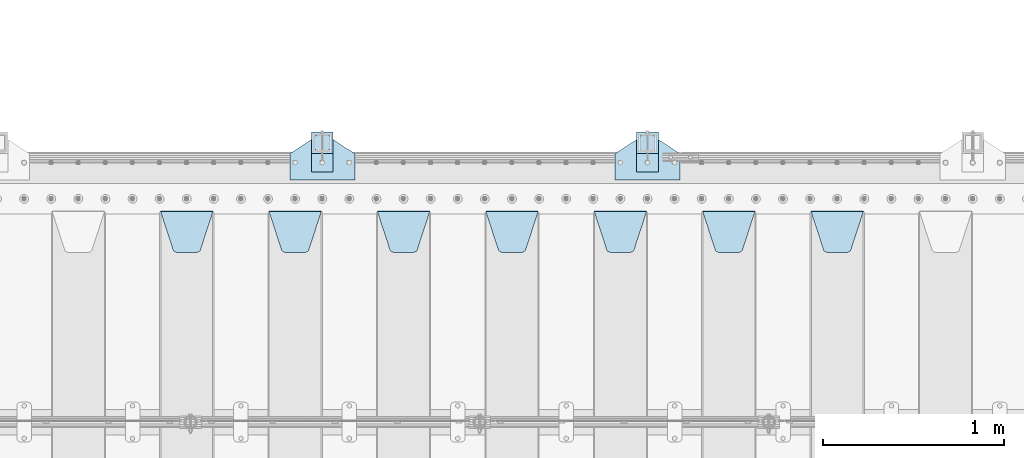
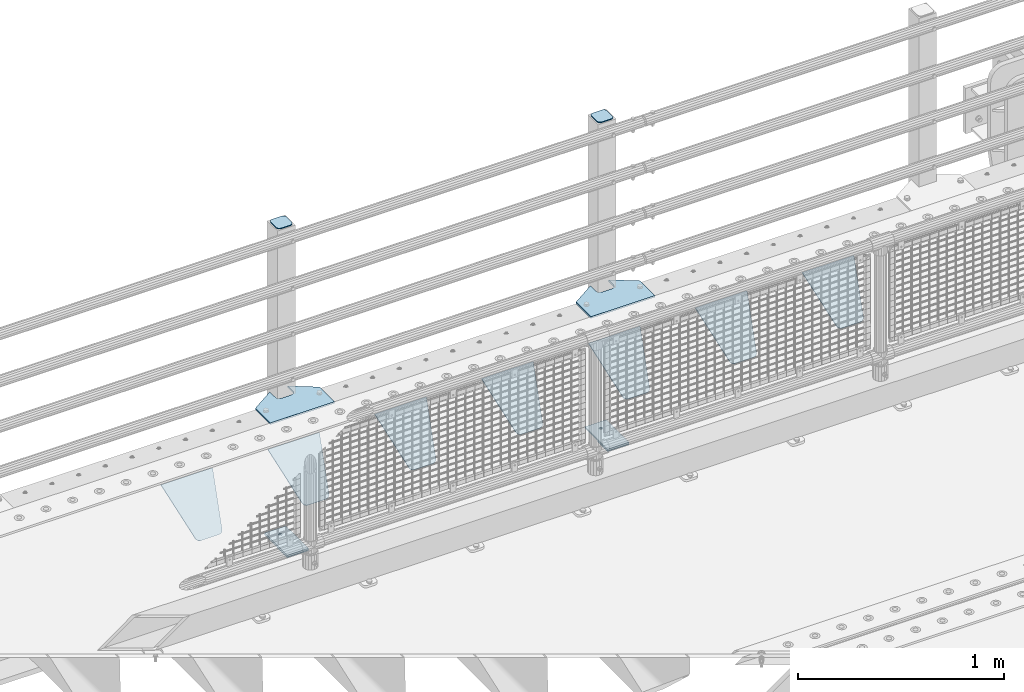
# One storey, part 230 of 257: 15 plates.
"""IFC2X3 building model written with IfcOpenShell, lengths in millimetres."""

from ifc_helpers import new_model, si_unit, frame, origin_with_axes, place, context, subcontext, project, spatial, faceted_brep, material, type_object, element, save


model = new_model("IFC2X3")

# Units and contexts
model_context = context("Model", 3, precision=1e-05, world=origin_with_axes())
body_context = subcontext(model_context, "Body", "Model", "MODEL_VIEW")
ifc_project = project(units=[si_unit("LENGTHUNIT", "METRE", prefix="MILLI"), si_unit("AREAUNIT", "SQUARE_METRE"), si_unit("VOLUMEUNIT", "CUBIC_METRE"), si_unit("MASSUNIT", "GRAM", prefix="KILO"), si_unit("TIMEUNIT", "SECOND"), si_unit("PLANEANGLEUNIT", "RADIAN"), si_unit("SOLIDANGLEUNIT", "STERADIAN"), si_unit("THERMODYNAMICTEMPERATUREUNIT", "DEGREE_CELSIUS"), si_unit("LUMINOUSINTENSITYUNIT", "LUMEN")], contexts=[model_context])

# Site, building, storey
site_placement = place(None, origin_with_axes())
site = spatial("IfcSite", under=ifc_project, at=site_placement, CompositionType="ELEMENT")
building_placement = place(site_placement, origin_with_axes())
building = spatial("IfcBuilding", under=site, at=building_placement, Name="Standard", CompositionType="ELEMENT")
storey_placement = place(building_placement, origin_with_axes())
storey = spatial("IfcBuildingStorey", under=building, at=storey_placement, Name="Undefined", CompositionType="ELEMENT", Elevation=0.0)

# Plates
ifc_material_1 = material(Name="STEEL/S355N")
plate_type_1 = type_object("IfcPlateType", PredefinedType="NOTDEFINED")
plate_1_placement = place(storey_placement, frame((52905.0, 11831.7677669559, -1.767766952965), z_axis=(0.0, -0.707106781186548, -0.707106781186547), x_axis=(1.0, 0.0, 0.0)))
element("IfcPlate", 1, at=plate_1_placement, inside=storey, type_object=plate_type_1, material=ifc_material_1, context=body_context, shape_type="Brep", body=[
    faceted_brep([(0.0, -2.5, 0.0), (69.345504679477, -2.50000000000091, 300.17173142483), (69.345504679477, 2.5, 300.171731424831), (0.0, 2.5, 0.0), (70.927406119954, -2.50000000000091, 304.8974424154), (70.927406119954, 2.5, 304.8974424154), (73.3818627772271, -2.50000000000091, 309.234538108527), (73.3818627772271, 2.49999999999909, 309.234538108527), (76.6187032999587, -2.5, 313.023683126103), (76.6187032999587, 2.5, 313.023683126103), (80.5190132705029, -2.5, 316.125672595372), (80.5190132705029, 2.5, 316.125672595371), (84.9395038596849, -2.5, 318.426546230476), (84.9395038596849, 2.5, 318.426546230477), (89.7177759439219, -2.5, 319.841774983275), (89.7177759439219, 2.5, 319.841774983275), (94.6782862926484, -2.5, 320.319366455079), (94.6782862926484, 2.5, 320.319366455079), (195.321713707352, -2.5, 320.319366455079), (195.321713707352, 2.5, 320.319366455079), (200.282224056078, -2.5, 319.841774983275), (200.282224056078, 2.49999999999909, 319.841774983275), (205.060496140315, -2.5, 318.426546230476), (205.060496140315, 2.49999999999909, 318.426546230475), (209.480986729497, -2.5, 316.125672595371), (209.480986729497, 2.5, 316.125672595371), (213.381296700041, -2.50000000000091, 313.023683126102), (213.381296700041, 2.5, 313.023683126103), (216.618137222766, -2.50000000000091, 309.234538108527), (216.618137222766, 2.5, 309.234538108527), (219.072593880039, -2.5, 304.897442415399), (219.072593880039, 2.5, 304.897442415399), (220.654495320523, -2.50000000000091, 300.17173142483), (220.654495320523, 2.5, 300.171731424831), (290.0, -2.50000000000091, 0.0), (290.0, 2.5, 9.09494701772928e-13)], [[[0, 1, 2, 3]], [[1, 4, 5, 2]], [[4, 6, 7, 5]], [[6, 8, 9, 7]], [[8, 10, 11, 9]], [[10, 12, 13, 11]], [[12, 14, 15, 13]], [[14, 16, 17, 15]], [[16, 18, 19, 17]], [[18, 20, 21, 19]], [[20, 22, 23, 21]], [[22, 24, 25, 23]], [[24, 26, 27, 25]], [[26, 28, 29, 27]], [[28, 30, 31, 29]], [[30, 32, 33, 31]], [[32, 34, 35, 33]], [[34, 0, 3, 35]], [[5, 7, 9, 11, 13, 15, 17, 19, 21, 23, 25, 27, 29, 31, 33, 35, 3, 2]], [[34, 32, 30, 28, 26, 24, 22, 20, 18, 16, 14, 12, 10, 8, 6, 4, 1, 0]]]),
])
plate_2_placement = place(storey_placement, frame((52305.0, 11831.7677669559, -1.767766952965), z_axis=(0.0, -0.707106781186548, -0.707106781186547), x_axis=(1.0, 0.0, 0.0)))
element("IfcPlate", 2, at=plate_2_placement, inside=storey, type_object=plate_type_1, material=ifc_material_1, context=body_context, shape_type="Brep", body=[
    faceted_brep([(0.0, -2.5, 0.0), (69.345504679477, -2.50000000000091, 300.17173142483), (69.345504679477, 2.5, 300.171731424831), (0.0, 2.5, 0.0), (70.927406119954, -2.50000000000091, 304.8974424154), (70.927406119954, 2.5, 304.8974424154), (73.3818627772271, -2.50000000000091, 309.234538108527), (73.3818627772271, 2.49999999999909, 309.234538108527), (76.6187032999587, -2.5, 313.023683126103), (76.6187032999587, 2.5, 313.023683126103), (80.5190132705029, -2.5, 316.125672595372), (80.5190132705029, 2.5, 316.125672595371), (84.9395038596849, -2.5, 318.426546230476), (84.9395038596849, 2.5, 318.426546230477), (89.7177759439219, -2.5, 319.841774983275), (89.7177759439219, 2.5, 319.841774983275), (94.6782862926484, -2.5, 320.319366455079), (94.6782862926484, 2.5, 320.319366455079), (195.321713707352, -2.5, 320.319366455079), (195.321713707352, 2.5, 320.319366455079), (200.282224056078, -2.5, 319.841774983275), (200.282224056078, 2.49999999999909, 319.841774983275), (205.060496140315, -2.5, 318.426546230476), (205.060496140315, 2.49999999999909, 318.426546230475), (209.480986729497, -2.5, 316.125672595371), (209.480986729497, 2.5, 316.125672595371), (213.381296700041, -2.50000000000091, 313.023683126102), (213.381296700041, 2.5, 313.023683126103), (216.618137222766, -2.50000000000091, 309.234538108527), (216.618137222766, 2.5, 309.234538108527), (219.072593880039, -2.5, 304.897442415399), (219.072593880039, 2.5, 304.897442415399), (220.654495320523, -2.50000000000091, 300.17173142483), (220.654495320523, 2.5, 300.171731424831), (290.0, -2.50000000000091, 0.0), (290.0, 2.5, 9.09494701772928e-13)], [[[0, 1, 2, 3]], [[1, 4, 5, 2]], [[4, 6, 7, 5]], [[6, 8, 9, 7]], [[8, 10, 11, 9]], [[10, 12, 13, 11]], [[12, 14, 15, 13]], [[14, 16, 17, 15]], [[16, 18, 19, 17]], [[18, 20, 21, 19]], [[20, 22, 23, 21]], [[22, 24, 25, 23]], [[24, 26, 27, 25]], [[26, 28, 29, 27]], [[28, 30, 31, 29]], [[30, 32, 33, 31]], [[32, 34, 35, 33]], [[34, 0, 3, 35]], [[5, 7, 9, 11, 13, 15, 17, 19, 21, 23, 25, 27, 29, 31, 33, 35, 3, 2]], [[34, 32, 30, 28, 26, 24, 22, 20, 18, 16, 14, 12, 10, 8, 6, 4, 1, 0]]]),
])
plate_3_placement = place(storey_placement, frame((51705.0, 11831.7677669559, -1.767766952965), z_axis=(0.0, -0.707106781186548, -0.707106781186547), x_axis=(1.0, 0.0, 0.0)))
element("IfcPlate", 3, at=plate_3_placement, inside=storey, type_object=plate_type_1, material=ifc_material_1, context=body_context, shape_type="Brep", body=[
    faceted_brep([(0.0, -2.5, 0.0), (69.345504679477, -2.50000000000091, 300.17173142483), (69.345504679477, 2.5, 300.171731424831), (0.0, 2.5, 0.0), (70.927406119954, -2.50000000000091, 304.8974424154), (70.927406119954, 2.5, 304.8974424154), (73.3818627772271, -2.50000000000091, 309.234538108527), (73.3818627772271, 2.49999999999909, 309.234538108527), (76.6187032999587, -2.5, 313.023683126103), (76.6187032999587, 2.5, 313.023683126103), (80.5190132705029, -2.5, 316.125672595372), (80.5190132705029, 2.5, 316.125672595371), (84.9395038596849, -2.5, 318.426546230476), (84.9395038596849, 2.5, 318.426546230477), (89.7177759439219, -2.5, 319.841774983275), (89.7177759439219, 2.5, 319.841774983275), (94.6782862926484, -2.5, 320.319366455079), (94.6782862926484, 2.5, 320.319366455079), (195.321713707352, -2.5, 320.319366455079), (195.321713707352, 2.5, 320.319366455079), (200.282224056078, -2.5, 319.841774983275), (200.282224056078, 2.49999999999909, 319.841774983275), (205.060496140315, -2.5, 318.426546230476), (205.060496140315, 2.49999999999909, 318.426546230475), (209.480986729497, -2.5, 316.125672595371), (209.480986729497, 2.5, 316.125672595371), (213.381296700041, -2.50000000000091, 313.023683126102), (213.381296700041, 2.5, 313.023683126103), (216.618137222766, -2.50000000000091, 309.234538108527), (216.618137222766, 2.5, 309.234538108527), (219.072593880039, -2.5, 304.897442415399), (219.072593880039, 2.5, 304.897442415399), (220.654495320523, -2.50000000000091, 300.17173142483), (220.654495320523, 2.5, 300.171731424831), (290.0, -2.50000000000091, 0.0), (290.0, 2.5, 9.09494701772928e-13)], [[[0, 1, 2, 3]], [[1, 4, 5, 2]], [[4, 6, 7, 5]], [[6, 8, 9, 7]], [[8, 10, 11, 9]], [[10, 12, 13, 11]], [[12, 14, 15, 13]], [[14, 16, 17, 15]], [[16, 18, 19, 17]], [[18, 20, 21, 19]], [[20, 22, 23, 21]], [[22, 24, 25, 23]], [[24, 26, 27, 25]], [[26, 28, 29, 27]], [[28, 30, 31, 29]], [[30, 32, 33, 31]], [[32, 34, 35, 33]], [[34, 0, 3, 35]], [[5, 7, 9, 11, 13, 15, 17, 19, 21, 23, 25, 27, 29, 31, 33, 35, 3, 2]], [[34, 32, 30, 28, 26, 24, 22, 20, 18, 16, 14, 12, 10, 8, 6, 4, 1, 0]]]),
])
plate_4_placement = place(storey_placement, frame((51105.0, 11831.7677669559, -1.767766952965), z_axis=(0.0, -0.707106781186548, -0.707106781186547), x_axis=(1.0, 0.0, 0.0)))
element("IfcPlate", 4, at=plate_4_placement, inside=storey, type_object=plate_type_1, material=ifc_material_1, context=body_context, shape_type="Brep", body=[
    faceted_brep([(0.0, -2.5, 0.0), (69.345504679477, -2.50000000000091, 300.17173142483), (69.345504679477, 2.5, 300.171731424831), (0.0, 2.5, 0.0), (70.927406119954, -2.50000000000091, 304.8974424154), (70.927406119954, 2.5, 304.8974424154), (73.3818627772271, -2.50000000000091, 309.234538108527), (73.3818627772271, 2.49999999999909, 309.234538108527), (76.6187032999587, -2.5, 313.023683126103), (76.6187032999587, 2.5, 313.023683126103), (80.5190132705029, -2.5, 316.125672595372), (80.5190132705029, 2.5, 316.125672595371), (84.9395038596849, -2.5, 318.426546230476), (84.9395038596849, 2.5, 318.426546230477), (89.7177759439219, -2.5, 319.841774983275), (89.7177759439219, 2.5, 319.841774983275), (94.6782862926484, -2.5, 320.319366455079), (94.6782862926484, 2.5, 320.319366455079), (195.321713707352, -2.5, 320.319366455079), (195.321713707352, 2.5, 320.319366455079), (200.282224056078, -2.5, 319.841774983275), (200.282224056078, 2.49999999999909, 319.841774983275), (205.060496140315, -2.5, 318.426546230476), (205.060496140315, 2.49999999999909, 318.426546230475), (209.480986729497, -2.5, 316.125672595371), (209.480986729497, 2.5, 316.125672595371), (213.381296700041, -2.50000000000091, 313.023683126102), (213.381296700041, 2.5, 313.023683126103), (216.618137222766, -2.50000000000091, 309.234538108527), (216.618137222766, 2.5, 309.234538108527), (219.072593880039, -2.5, 304.897442415399), (219.072593880039, 2.5, 304.897442415399), (220.654495320523, -2.50000000000091, 300.17173142483), (220.654495320523, 2.5, 300.171731424831), (290.0, -2.50000000000091, 0.0), (290.0, 2.5, 9.09494701772928e-13)], [[[0, 1, 2, 3]], [[1, 4, 5, 2]], [[4, 6, 7, 5]], [[6, 8, 9, 7]], [[8, 10, 11, 9]], [[10, 12, 13, 11]], [[12, 14, 15, 13]], [[14, 16, 17, 15]], [[16, 18, 19, 17]], [[18, 20, 21, 19]], [[20, 22, 23, 21]], [[22, 24, 25, 23]], [[24, 26, 27, 25]], [[26, 28, 29, 27]], [[28, 30, 31, 29]], [[30, 32, 33, 31]], [[32, 34, 35, 33]], [[34, 0, 3, 35]], [[5, 7, 9, 11, 13, 15, 17, 19, 21, 23, 25, 27, 29, 31, 33, 35, 3, 2]], [[34, 32, 30, 28, 26, 24, 22, 20, 18, 16, 14, 12, 10, 8, 6, 4, 1, 0]]]),
])
plate_5_placement = place(storey_placement, frame((50505.0, 11831.7677669559, -1.767766952965), z_axis=(0.0, -0.707106781186548, -0.707106781186547), x_axis=(1.0, 0.0, 0.0)))
element("IfcPlate", 5, at=plate_5_placement, inside=storey, type_object=plate_type_1, material=ifc_material_1, context=body_context, shape_type="Brep", body=[
    faceted_brep([(0.0, -2.5, 0.0), (69.345504679477, -2.50000000000091, 300.17173142483), (69.345504679477, 2.5, 300.171731424831), (0.0, 2.5, 0.0), (70.927406119954, -2.50000000000091, 304.8974424154), (70.927406119954, 2.5, 304.8974424154), (73.3818627772271, -2.50000000000091, 309.234538108527), (73.3818627772271, 2.49999999999909, 309.234538108527), (76.6187032999587, -2.5, 313.023683126103), (76.6187032999587, 2.5, 313.023683126103), (80.5190132705029, -2.5, 316.125672595372), (80.5190132705029, 2.5, 316.125672595371), (84.9395038596849, -2.5, 318.426546230476), (84.9395038596849, 2.5, 318.426546230477), (89.7177759439219, -2.5, 319.841774983275), (89.7177759439219, 2.5, 319.841774983275), (94.6782862926484, -2.5, 320.319366455079), (94.6782862926484, 2.5, 320.319366455079), (195.321713707352, -2.5, 320.319366455079), (195.321713707352, 2.5, 320.319366455079), (200.282224056078, -2.5, 319.841774983275), (200.282224056078, 2.49999999999909, 319.841774983275), (205.060496140315, -2.5, 318.426546230476), (205.060496140315, 2.49999999999909, 318.426546230475), (209.480986729497, -2.5, 316.125672595371), (209.480986729497, 2.5, 316.125672595371), (213.381296700041, -2.50000000000091, 313.023683126102), (213.381296700041, 2.5, 313.023683126103), (216.618137222766, -2.50000000000091, 309.234538108527), (216.618137222766, 2.5, 309.234538108527), (219.072593880039, -2.5, 304.897442415399), (219.072593880039, 2.5, 304.897442415399), (220.654495320523, -2.50000000000091, 300.17173142483), (220.654495320523, 2.5, 300.171731424831), (290.0, -2.50000000000091, 0.0), (290.0, 2.5, 9.09494701772928e-13)], [[[0, 1, 2, 3]], [[1, 4, 5, 2]], [[4, 6, 7, 5]], [[6, 8, 9, 7]], [[8, 10, 11, 9]], [[10, 12, 13, 11]], [[12, 14, 15, 13]], [[14, 16, 17, 15]], [[16, 18, 19, 17]], [[18, 20, 21, 19]], [[20, 22, 23, 21]], [[22, 24, 25, 23]], [[24, 26, 27, 25]], [[26, 28, 29, 27]], [[28, 30, 31, 29]], [[30, 32, 33, 31]], [[32, 34, 35, 33]], [[34, 0, 3, 35]], [[5, 7, 9, 11, 13, 15, 17, 19, 21, 23, 25, 27, 29, 31, 33, 35, 3, 2]], [[34, 32, 30, 28, 26, 24, 22, 20, 18, 16, 14, 12, 10, 8, 6, 4, 1, 0]]]),
])
plate_6_placement = place(storey_placement, frame((49905.0, 11831.7677669559, -1.767766952965), z_axis=(0.0, -0.707106781186548, -0.707106781186547), x_axis=(1.0, 0.0, 0.0)))
element("IfcPlate", 6, at=plate_6_placement, inside=storey, type_object=plate_type_1, material=ifc_material_1, context=body_context, shape_type="Brep", body=[
    faceted_brep([(0.0, -2.5, 0.0), (69.345504679477, -2.50000000000091, 300.17173142483), (69.345504679477, 2.5, 300.171731424831), (0.0, 2.5, 0.0), (70.927406119954, -2.50000000000091, 304.8974424154), (70.927406119954, 2.5, 304.8974424154), (73.3818627772271, -2.50000000000091, 309.234538108527), (73.3818627772271, 2.49999999999909, 309.234538108527), (76.6187032999587, -2.5, 313.023683126103), (76.6187032999587, 2.5, 313.023683126103), (80.5190132705029, -2.5, 316.125672595372), (80.5190132705029, 2.5, 316.125672595371), (84.9395038596849, -2.5, 318.426546230476), (84.9395038596849, 2.5, 318.426546230477), (89.7177759439219, -2.5, 319.841774983275), (89.7177759439219, 2.5, 319.841774983275), (94.6782862926484, -2.5, 320.319366455079), (94.6782862926484, 2.5, 320.319366455079), (195.321713707352, -2.5, 320.319366455079), (195.321713707352, 2.5, 320.319366455079), (200.282224056078, -2.5, 319.841774983275), (200.282224056078, 2.49999999999909, 319.841774983275), (205.060496140315, -2.5, 318.426546230476), (205.060496140315, 2.49999999999909, 318.426546230475), (209.480986729497, -2.5, 316.125672595371), (209.480986729497, 2.5, 316.125672595371), (213.381296700041, -2.50000000000091, 313.023683126102), (213.381296700041, 2.5, 313.023683126103), (216.618137222766, -2.50000000000091, 309.234538108527), (216.618137222766, 2.5, 309.234538108527), (219.072593880039, -2.5, 304.897442415399), (219.072593880039, 2.5, 304.897442415399), (220.654495320523, -2.50000000000091, 300.17173142483), (220.654495320523, 2.5, 300.171731424831), (290.0, -2.50000000000091, 0.0), (290.0, 2.5, 9.09494701772928e-13)], [[[0, 1, 2, 3]], [[1, 4, 5, 2]], [[4, 6, 7, 5]], [[6, 8, 9, 7]], [[8, 10, 11, 9]], [[10, 12, 13, 11]], [[12, 14, 15, 13]], [[14, 16, 17, 15]], [[16, 18, 19, 17]], [[18, 20, 21, 19]], [[20, 22, 23, 21]], [[22, 24, 25, 23]], [[24, 26, 27, 25]], [[26, 28, 29, 27]], [[28, 30, 31, 29]], [[30, 32, 33, 31]], [[32, 34, 35, 33]], [[34, 0, 3, 35]], [[5, 7, 9, 11, 13, 15, 17, 19, 21, 23, 25, 27, 29, 31, 33, 35, 3, 2]], [[34, 32, 30, 28, 26, 24, 22, 20, 18, 16, 14, 12, 10, 8, 6, 4, 1, 0]]]),
])
plate_7_placement = place(storey_placement, frame((49305.0, 11831.7677669559, -1.767766952965), z_axis=(0.0, -0.707106781186548, -0.707106781186547), x_axis=(1.0, 0.0, 0.0)))
element("IfcPlate", 7, at=plate_7_placement, inside=storey, type_object=plate_type_1, material=ifc_material_1, context=body_context, shape_type="Brep", body=[
    faceted_brep([(0.0, -2.5, 0.0), (69.345504679477, -2.50000000000091, 300.17173142483), (69.345504679477, 2.5, 300.171731424831), (0.0, 2.5, 0.0), (70.927406119954, -2.50000000000091, 304.8974424154), (70.927406119954, 2.5, 304.8974424154), (73.3818627772271, -2.50000000000091, 309.234538108527), (73.3818627772271, 2.49999999999909, 309.234538108527), (76.6187032999587, -2.5, 313.023683126103), (76.6187032999587, 2.5, 313.023683126103), (80.5190132705029, -2.5, 316.125672595372), (80.5190132705029, 2.5, 316.125672595371), (84.9395038596849, -2.5, 318.426546230476), (84.9395038596849, 2.5, 318.426546230477), (89.7177759439219, -2.5, 319.841774983275), (89.7177759439219, 2.5, 319.841774983275), (94.6782862926484, -2.5, 320.319366455079), (94.6782862926484, 2.5, 320.319366455079), (195.321713707352, -2.5, 320.319366455079), (195.321713707352, 2.5, 320.319366455079), (200.282224056078, -2.5, 319.841774983275), (200.282224056078, 2.49999999999909, 319.841774983275), (205.060496140315, -2.5, 318.426546230476), (205.060496140315, 2.49999999999909, 318.426546230475), (209.480986729497, -2.5, 316.125672595371), (209.480986729497, 2.5, 316.125672595371), (213.381296700041, -2.50000000000091, 313.023683126102), (213.381296700041, 2.5, 313.023683126103), (216.618137222766, -2.50000000000091, 309.234538108527), (216.618137222766, 2.5, 309.234538108527), (219.072593880039, -2.5, 304.897442415399), (219.072593880039, 2.5, 304.897442415399), (220.654495320523, -2.50000000000091, 300.17173142483), (220.654495320523, 2.5, 300.171731424831), (290.0, -2.50000000000091, 0.0), (290.0, 2.5, 9.09494701772928e-13)], [[[0, 1, 2, 3]], [[1, 4, 5, 2]], [[4, 6, 7, 5]], [[6, 8, 9, 7]], [[8, 10, 11, 9]], [[10, 12, 13, 11]], [[12, 14, 15, 13]], [[14, 16, 17, 15]], [[16, 18, 19, 17]], [[18, 20, 21, 19]], [[20, 22, 23, 21]], [[22, 24, 25, 23]], [[24, 26, 27, 25]], [[26, 28, 29, 27]], [[28, 30, 31, 29]], [[30, 32, 33, 31]], [[32, 34, 35, 33]], [[34, 0, 3, 35]], [[5, 7, 9, 11, 13, 15, 17, 19, 21, 23, 25, 27, 29, 31, 33, 35, 3, 2]], [[34, 32, 30, 28, 26, 24, 22, 20, 18, 16, 14, 12, 10, 8, 6, 4, 1, 0]]]),
])
ifc_material_2 = material(Name="STEEL/S355J2")
plate_type_2 = type_object("IfcPlateType", PredefinedType="NOTDEFINED")
plate_8_placement = place(storey_placement, frame((51820.0, 12005.0, 5.00000000004911), z_axis=(0.0, 1.0, 0.0), x_axis=(1.0, 0.0, 0.0)))
element("IfcPlate", 8, at=plate_8_placement, inside=storey, type_object=plate_type_2, material=ifc_material_2, context=body_context, shape_type="Brep", body=[
    faceted_brep([(0.0, -5.0, 0.0), (2.31396552408114e-06, -5.0, 145.0), (2.31396552408114e-06, 5.0, 145.0), (0.0, 5.0, 0.0), (130.0, -5.0, 230.0), (130.0, 5.0, 230.0), (130.0, -5.0, 180.0), (130.0, 5.0, 180.0), (130.48036798992, -5.0, 175.122741949597), (130.48036798992, 5.0, 175.122741949597), (131.903011687216, -5.0, 170.432914190873), (131.903011687216, 5.0, 170.432914190873), (134.213259692435, -5.0, 166.11074417451), (134.213259692435, 5.0, 166.11074417451), (137.322330470335, -5.0, 162.322330470337), (137.322330470335, 5.0, 162.322330470337), (141.110744174512, -5.0, 159.213259692437), (141.110744174512, 5.0, 159.213259692437), (145.432914190875, -5.0, 156.903011687218), (145.432914190875, 5.0, 156.903011687218), (150.122741949599, -5.0, 155.48036798992), (150.122741949599, 5.0, 155.48036798992), (155.0, -5.0, 155.0), (155.0, 5.0, 155.0), (205.0, -5.0, 155.0), (205.0, 5.0, 155.0), (209.877258050401, -5.0, 155.48036798992), (209.877258050401, 5.0, 155.48036798992), (214.567085809125, -5.0, 156.903011687218), (214.567085809125, 5.0, 156.903011687218), (218.889255825488, -5.0, 159.213259692437), (218.889255825488, 5.0, 159.213259692437), (222.677669529665, -5.0, 162.322330470337), (222.677669529665, 5.0, 162.322330470337), (225.786740307565, -5.0, 166.11074417451), (225.786740307565, 5.0, 166.11074417451), (228.096988312784, -5.0, 170.432914190873), (228.096988312784, 5.0, 170.432914190873), (229.51963201008, -5.0, 175.122741949597), (229.51963201008, 5.0, 175.122741949597), (230.0, -5.0, 180.0), (230.0, 5.0, 180.0), (230.0, -5.0, 230.0), (230.0, 5.0, 230.0), (360.0, -5.0, 145.0), (360.0, 5.0, 145.0), (360.0, -5.0, -7.27595761418343e-12), (360.0, 5.0, -7.27595761418343e-12)], [[[0, 1, 2, 3]], [[1, 4, 5, 2]], [[4, 6, 7, 5]], [[6, 8, 9, 7]], [[8, 10, 11, 9]], [[10, 12, 13, 11]], [[12, 14, 15, 13]], [[14, 16, 17, 15]], [[16, 18, 19, 17]], [[18, 20, 21, 19]], [[20, 22, 23, 21]], [[22, 24, 25, 23]], [[24, 26, 27, 25]], [[26, 28, 29, 27]], [[28, 30, 31, 29]], [[30, 32, 33, 31]], [[32, 34, 35, 33]], [[34, 36, 37, 35]], [[36, 38, 39, 37]], [[38, 40, 41, 39]], [[40, 42, 43, 41]], [[42, 44, 45, 43]], [[44, 46, 47, 45]], [[46, 0, 3, 47]], [[5, 7, 9, 11, 13, 15, 17, 19, 21, 23, 25, 27, 29, 31, 33, 35, 37, 39, 41, 43, 45, 47, 3, 2]], [[46, 44, 42, 40, 38, 36, 34, 32, 30, 28, 26, 24, 22, 20, 18, 16, 14, 12, 10, 8, 6, 4, 1, 0]]]),
])
plate_9_placement = place(storey_placement, frame((50020.0, 12005.0, 5.00000000004911), z_axis=(0.0, 1.0, 0.0), x_axis=(1.0, 0.0, 0.0)))
element("IfcPlate", 9, at=plate_9_placement, inside=storey, type_object=plate_type_2, material=ifc_material_2, context=body_context, shape_type="Brep", body=[
    faceted_brep([(0.0, -5.0, 0.0), (2.31396552408114e-06, -5.0, 145.0), (2.31396552408114e-06, 5.0, 145.0), (0.0, 5.0, 0.0), (130.0, -5.0, 230.0), (130.0, 5.0, 230.0), (130.0, -5.0, 180.0), (130.0, 5.0, 180.0), (130.48036798992, -5.0, 175.122741949597), (130.48036798992, 5.0, 175.122741949597), (131.903011687216, -5.0, 170.432914190873), (131.903011687216, 5.0, 170.432914190873), (134.213259692435, -5.0, 166.11074417451), (134.213259692435, 5.0, 166.11074417451), (137.322330470335, -5.0, 162.322330470337), (137.322330470335, 5.0, 162.322330470337), (141.110744174512, -5.0, 159.213259692437), (141.110744174512, 5.0, 159.213259692437), (145.432914190875, -5.0, 156.903011687218), (145.432914190875, 5.0, 156.903011687218), (150.122741949599, -5.0, 155.48036798992), (150.122741949599, 5.0, 155.48036798992), (155.0, -5.0, 155.0), (155.0, 5.0, 155.0), (205.0, -5.0, 155.0), (205.0, 5.0, 155.0), (209.877258050401, -5.0, 155.48036798992), (209.877258050401, 5.0, 155.48036798992), (214.567085809125, -5.0, 156.903011687218), (214.567085809125, 5.0, 156.903011687218), (218.889255825488, -5.0, 159.213259692437), (218.889255825488, 5.0, 159.213259692437), (222.677669529665, -5.0, 162.322330470337), (222.677669529665, 5.0, 162.322330470337), (225.786740307565, -5.0, 166.11074417451), (225.786740307565, 5.0, 166.11074417451), (228.096988312784, -5.0, 170.432914190873), (228.096988312784, 5.0, 170.432914190873), (229.51963201008, -5.0, 175.122741949597), (229.51963201008, 5.0, 175.122741949597), (230.0, -5.0, 180.0), (230.0, 5.0, 180.0), (230.0, -5.0, 230.0), (230.0, 5.0, 230.0), (360.0, -5.0, 145.0), (360.0, 5.0, 145.0), (360.0, -5.0, -7.27595761418343e-12), (360.0, 5.0, -7.27595761418343e-12)], [[[0, 1, 2, 3]], [[1, 4, 5, 2]], [[4, 6, 7, 5]], [[6, 8, 9, 7]], [[8, 10, 11, 9]], [[10, 12, 13, 11]], [[12, 14, 15, 13]], [[14, 16, 17, 15]], [[16, 18, 19, 17]], [[18, 20, 21, 19]], [[20, 22, 23, 21]], [[22, 24, 25, 23]], [[24, 26, 27, 25]], [[26, 28, 29, 27]], [[28, 30, 31, 29]], [[30, 32, 33, 31]], [[32, 34, 35, 33]], [[34, 36, 37, 35]], [[36, 38, 39, 37]], [[38, 40, 41, 39]], [[40, 42, 43, 41]], [[42, 44, 45, 43]], [[44, 46, 47, 45]], [[46, 0, 3, 47]], [[5, 7, 9, 11, 13, 15, 17, 19, 21, 23, 25, 27, 29, 31, 33, 35, 37, 39, 41, 43, 45, 47, 3, 2]], [[46, 44, 42, 40, 38, 36, 34, 32, 30, 28, 26, 24, 22, 20, 18, 16, 14, 12, 10, 8, 6, 4, 1, 0]]]),
])
plate_type_3 = type_object("IfcPlateType", PredefinedType="NOTDEFINED")
for number, where, z_axis, x_axis in (
    (10, (51940.0000000001, 12050.0000000002, -850.000000000002), (0.0, 1.0, 0.0), (1.0, 0.0, 0.0)),
    (11, (50140.0000000001, 12050.0000000002, -850.000000000002), (0.0, 1.0, 0.0), (1.0, 0.0, 0.0)),
):
    element("IfcPlate", number, at=place(storey_placement, frame(where, z_axis=z_axis, x_axis=x_axis)), inside=storey, type_object=plate_type_3, material=ifc_material_2, context=body_context, shape_type="Brep", body=[
        faceted_brep([(66.3639610305399, -5.0, 163.636038969113), (66.3639610305399, 5.0, 163.636038969113), (59.9999999998618, 5.0, 160.999999999791), (59.9999999998618, -5.0, 160.999999999791), (53.6360389691836, 5.0, 163.636038969113), (53.6360389691836, -5.0, 163.636038969113), (50.9999999998618, 5.0, 169.999999999791), (50.9999999998618, -5.0, 169.999999999791), (53.6360389691836, 5.0, 176.363961030469), (53.6360389691836, -5.0, 176.363961030469), (59.9999999998618, 5.0, 178.999999999791), (59.9999999998618, -5.0, 178.999999999791), (66.3639610305399, 5.0, 176.363961030469), (66.3639610305399, -5.0, 176.363961030469), (68.9999999998618, 5.0, 169.999999999791), (68.9999999998618, -5.0, 169.999999999791), (120.0, -5.0, 0.0), (120.0, -5.0, 220.0), (0.0, -5.0, 220.0), (0.0, -5.0, 0.0), (0.0, 5.0, 0.0), (120.0, 5.0, 0.0), (120.0, 5.0, 220.0), (0.0, 5.0, 220.0)], [[[0, 1, 2, 3]], [[3, 2, 4, 5]], [[5, 4, 6, 7]], [[7, 6, 8, 9]], [[9, 8, 10, 11]], [[11, 10, 12, 13]], [[13, 12, 14, 15]], [[15, 14, 1, 0]], [[16, 17, 18, 19], [3, 5, 7, 9, 11, 13, 15, 0]], [[16, 19, 20, 21]], [[17, 16, 21, 22]], [[18, 17, 22, 23]], [[19, 18, 23, 20]], [[22, 21, 20, 23], [10, 8, 6, 4, 2, 1, 14, 12]]]),
    ])
plate_type_4 = type_object("IfcPlateType", PredefinedType="NOTDEFINED")
plate_10_placement = place(storey_placement, frame((52044.0000000001, 12166.0000000002, 1012.50000000001), z_axis=(0.0, 1.0, 0.0), x_axis=(-1.0, 0.0, 0.0)))
element("IfcPlate", 12, at=plate_10_placement, inside=storey, type_object=plate_type_4, material=ifc_material_2, context=body_context, shape_type="Brep", body=[
    faceted_brep([(0.0, -2.5, 19.0), (0.0, -2.5, 69.0), (0.0, 2.5, 69.0), (0.0, 2.5, 19.0), (0.476369668547704, -2.5, 73.2278977451697), (0.476369668547704, 2.5, 73.2278977451697), (1.88159150985302, -2.5, 77.2437910432327), (1.88159150985302, 2.5, 77.2437910432327), (4.14520183311106, -2.5, 80.8463062353167), (4.14520183311106, 2.5, 80.8463062353167), (7.15369376468152, -2.5, 83.8547981668926), (7.15369376468152, 2.5, 83.8547981668926), (10.7562089567655, -2.5, 86.1184084901452), (10.7562089567655, 2.5, 86.1184084901452), (14.7721022548285, -2.5, 87.5236303314541), (14.7721022548285, 2.5, 87.5236303314541), (19.0, -2.5, 88.0), (19.0, 2.5, 88.0), (69.0, -2.5, 88.0), (69.0, 2.5, 88.0), (73.2278977451715, -2.5, 87.5236303314541), (73.2278977451715, 2.5, 87.5236303314541), (77.2437910432345, -2.5, 86.1184084901452), (77.2437910432345, 2.5, 86.1184084901452), (80.8463062353185, -2.5, 83.8547981668926), (80.8463062353185, 2.5, 83.8547981668926), (83.8547981668889, -2.5, 80.8463062353167), (83.8547981668889, 2.5, 80.8463062353167), (86.118408490147, -2.5, 77.2437910432327), (86.118408490147, 2.5, 77.2437910432327), (87.5236303314523, -2.5, 73.2278977451697), (87.5236303314523, 2.5, 73.2278977451697), (88.0, -2.5, 69.0), (88.0, 2.5, 69.0), (88.0, -2.5, 19.0), (88.0, 2.5, 19.0), (87.5236303314523, -2.5, 14.7721022548303), (87.5236303314523, 2.5, 14.7721022548303), (86.118408490147, -2.5, 10.7562089567673), (86.118408490147, 2.5, 10.7562089567673), (83.8547981668889, -2.5, 7.15369376468334), (83.8547981668889, 2.5, 7.15369376468334), (80.8463062353185, -2.5, 4.14520183310742), (80.8463062353185, 2.5, 4.14520183310742), (77.2437910432345, -2.5, 1.88159150985484), (77.2437910432345, 2.5, 1.88159150985484), (73.2278977451715, -2.5, 0.476369668545885), (73.2278977451715, 2.5, 0.476369668545885), (69.0, -2.5, 0.0), (69.0, 2.5, 0.0), (19.0, -2.5, 0.0), (19.0, 2.5, 0.0), (14.7721022548285, -2.5, 0.476369668545885), (14.7721022548285, 2.5, 0.476369668545885), (10.7562089567655, -2.5, 1.88159150985484), (10.7562089567655, 2.5, 1.88159150985484), (7.15369376468152, -2.5, 4.14520183310742), (7.15369376468152, 2.5, 4.14520183310742), (4.14520183311106, -2.5, 7.15369376468334), (4.14520183311106, 2.5, 7.15369376468334), (1.88159150985302, -2.5, 10.7562089567673), (1.88159150985302, 2.5, 10.7562089567673), (0.476369668547704, -2.5, 14.7721022548303), (0.476369668547704, 2.5, 14.7721022548303)], [[[0, 1, 2, 3]], [[1, 4, 5, 2]], [[4, 6, 7, 5]], [[6, 8, 9, 7]], [[8, 10, 11, 9]], [[10, 12, 13, 11]], [[12, 14, 15, 13]], [[14, 16, 17, 15]], [[16, 18, 19, 17]], [[18, 20, 21, 19]], [[20, 22, 23, 21]], [[22, 24, 25, 23]], [[24, 26, 27, 25]], [[26, 28, 29, 27]], [[28, 30, 31, 29]], [[30, 32, 33, 31]], [[32, 34, 35, 33]], [[34, 36, 37, 35]], [[36, 38, 39, 37]], [[38, 40, 41, 39]], [[40, 42, 43, 41]], [[42, 44, 45, 43]], [[44, 46, 47, 45]], [[46, 48, 49, 47]], [[48, 50, 51, 49]], [[50, 52, 53, 51]], [[52, 54, 55, 53]], [[54, 56, 57, 55]], [[56, 58, 59, 57]], [[58, 60, 61, 59]], [[60, 62, 63, 61]], [[62, 0, 3, 63]], [[5, 7, 9, 11, 13, 15, 17, 19, 21, 23, 25, 27, 29, 31, 33, 35, 37, 39, 41, 43, 45, 47, 49, 51, 53, 55, 57, 59, 61, 63, 3, 2]], [[62, 60, 58, 56, 54, 52, 50, 48, 46, 44, 42, 40, 38, 36, 34, 32, 30, 28, 26, 24, 22, 20, 18, 16, 14, 12, 10, 8, 6, 4, 1, 0]]]),
])
plate_11_placement = place(storey_placement, frame((50244.0000000001, 12166.0000000002, 1012.50000000001), z_axis=(0.0, 1.0, 0.0), x_axis=(-1.0, 0.0, 0.0)))
element("IfcPlate", 13, at=plate_11_placement, inside=storey, type_object=plate_type_4, material=ifc_material_2, context=body_context, shape_type="Brep", body=[
    faceted_brep([(0.0, -2.5, 19.0), (0.0, -2.5, 69.0), (0.0, 2.5, 69.0), (0.0, 2.5, 19.0), (0.476369668547704, -2.5, 73.2278977451697), (0.476369668547704, 2.5, 73.2278977451697), (1.88159150985302, -2.5, 77.2437910432327), (1.88159150985302, 2.5, 77.2437910432327), (4.14520183311106, -2.5, 80.8463062353167), (4.14520183311106, 2.5, 80.8463062353167), (7.15369376468152, -2.5, 83.8547981668926), (7.15369376468152, 2.5, 83.8547981668926), (10.7562089567655, -2.5, 86.1184084901452), (10.7562089567655, 2.5, 86.1184084901452), (14.7721022548285, -2.5, 87.5236303314541), (14.7721022548285, 2.5, 87.5236303314541), (19.0, -2.5, 88.0), (19.0, 2.5, 88.0), (69.0, -2.5, 88.0), (69.0, 2.5, 88.0), (73.2278977451715, -2.5, 87.5236303314541), (73.2278977451715, 2.5, 87.5236303314541), (77.2437910432345, -2.5, 86.1184084901452), (77.2437910432345, 2.5, 86.1184084901452), (80.8463062353185, -2.5, 83.8547981668926), (80.8463062353185, 2.5, 83.8547981668926), (83.8547981668889, -2.5, 80.8463062353167), (83.8547981668889, 2.5, 80.8463062353167), (86.118408490147, -2.5, 77.2437910432327), (86.118408490147, 2.5, 77.2437910432327), (87.5236303314523, -2.5, 73.2278977451697), (87.5236303314523, 2.5, 73.2278977451697), (88.0, -2.5, 69.0), (88.0, 2.5, 69.0), (88.0, -2.5, 19.0), (88.0, 2.5, 19.0), (87.5236303314523, -2.5, 14.7721022548303), (87.5236303314523, 2.5, 14.7721022548303), (86.118408490147, -2.5, 10.7562089567673), (86.118408490147, 2.5, 10.7562089567673), (83.8547981668889, -2.5, 7.15369376468334), (83.8547981668889, 2.5, 7.15369376468334), (80.8463062353185, -2.5, 4.14520183310742), (80.8463062353185, 2.5, 4.14520183310742), (77.2437910432345, -2.5, 1.88159150985484), (77.2437910432345, 2.5, 1.88159150985484), (73.2278977451715, -2.5, 0.476369668545885), (73.2278977451715, 2.5, 0.476369668545885), (69.0, -2.5, 0.0), (69.0, 2.5, 0.0), (19.0, -2.5, 0.0), (19.0, 2.5, 0.0), (14.7721022548285, -2.5, 0.476369668545885), (14.7721022548285, 2.5, 0.476369668545885), (10.7562089567655, -2.5, 1.88159150985484), (10.7562089567655, 2.5, 1.88159150985484), (7.15369376468152, -2.5, 4.14520183310742), (7.15369376468152, 2.5, 4.14520183310742), (4.14520183311106, -2.5, 7.15369376468334), (4.14520183311106, 2.5, 7.15369376468334), (1.88159150985302, -2.5, 10.7562089567673), (1.88159150985302, 2.5, 10.7562089567673), (0.476369668547704, -2.5, 14.7721022548303), (0.476369668547704, 2.5, 14.7721022548303)], [[[0, 1, 2, 3]], [[1, 4, 5, 2]], [[4, 6, 7, 5]], [[6, 8, 9, 7]], [[8, 10, 11, 9]], [[10, 12, 13, 11]], [[12, 14, 15, 13]], [[14, 16, 17, 15]], [[16, 18, 19, 17]], [[18, 20, 21, 19]], [[20, 22, 23, 21]], [[22, 24, 25, 23]], [[24, 26, 27, 25]], [[26, 28, 29, 27]], [[28, 30, 31, 29]], [[30, 32, 33, 31]], [[32, 34, 35, 33]], [[34, 36, 37, 35]], [[36, 38, 39, 37]], [[38, 40, 41, 39]], [[40, 42, 43, 41]], [[42, 44, 45, 43]], [[44, 46, 47, 45]], [[46, 48, 49, 47]], [[48, 50, 51, 49]], [[50, 52, 53, 51]], [[52, 54, 55, 53]], [[54, 56, 57, 55]], [[56, 58, 59, 57]], [[58, 60, 61, 59]], [[60, 62, 63, 61]], [[62, 0, 3, 63]], [[5, 7, 9, 11, 13, 15, 17, 19, 21, 23, 25, 27, 29, 31, 33, 35, 37, 39, 41, 43, 45, 47, 49, 51, 53, 55, 57, 59, 61, 63, 3, 2]], [[62, 60, 58, 56, 54, 52, 50, 48, 46, 44, 42, 40, 38, 36, 34, 32, 30, 28, 26, 24, 22, 20, 18, 16, 14, 12, 10, 8, 6, 4, 1, 0]]]),
])
plate_type_5 = type_object("IfcPlateType", PredefinedType="NOTDEFINED")
for number, where, z_axis, x_axis in (
    (14, (51940.0000000001, 12050.0000000002, -857.500000000002), (0.0, 1.0, 0.0), (1.0, 0.0, 0.0)),
    (15, (50140.0000000001, 12050.0000000002, -857.500000000002), (0.0, 1.0, 0.0), (1.0, 0.0, 0.0)),
):
    element("IfcPlate", number, at=place(storey_placement, frame(where, z_axis=z_axis, x_axis=x_axis)), inside=storey, type_object=plate_type_5, material=ifc_material_2, context=body_context, shape_type="Brep", body=[
        faceted_brep([(0.0, -2.5, 0.0), (0.0, -2.5, 100.0), (0.0, 2.5, 100.0), (0.0, 2.5, 0.0), (120.0, -2.5, 100.0), (120.0, 2.5, 100.0), (120.0, -2.5, 0.0), (120.0, 2.5, 0.0)], [[[0, 1, 2, 3]], [[1, 4, 5, 2]], [[4, 6, 7, 5]], [[6, 0, 3, 7]], [[5, 7, 3, 2]], [[6, 4, 1, 0]]]),
    ])

save(model, "model.ifc")
